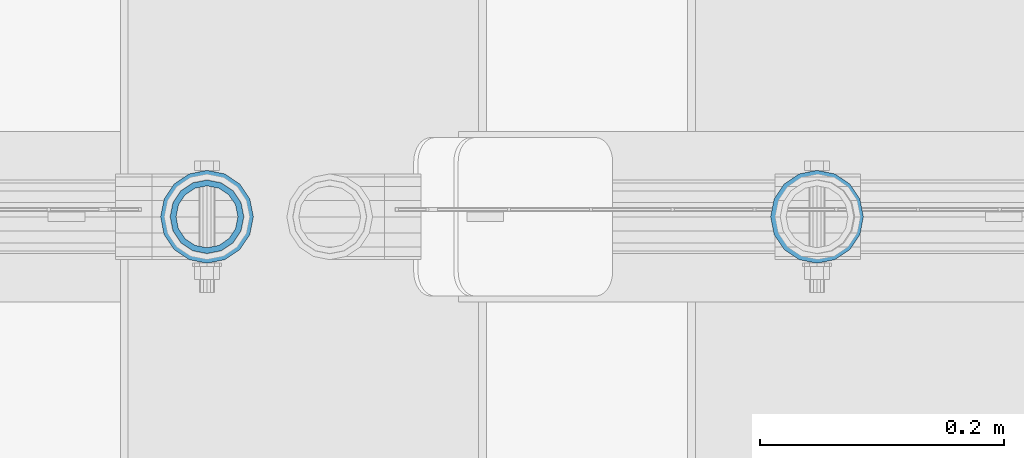
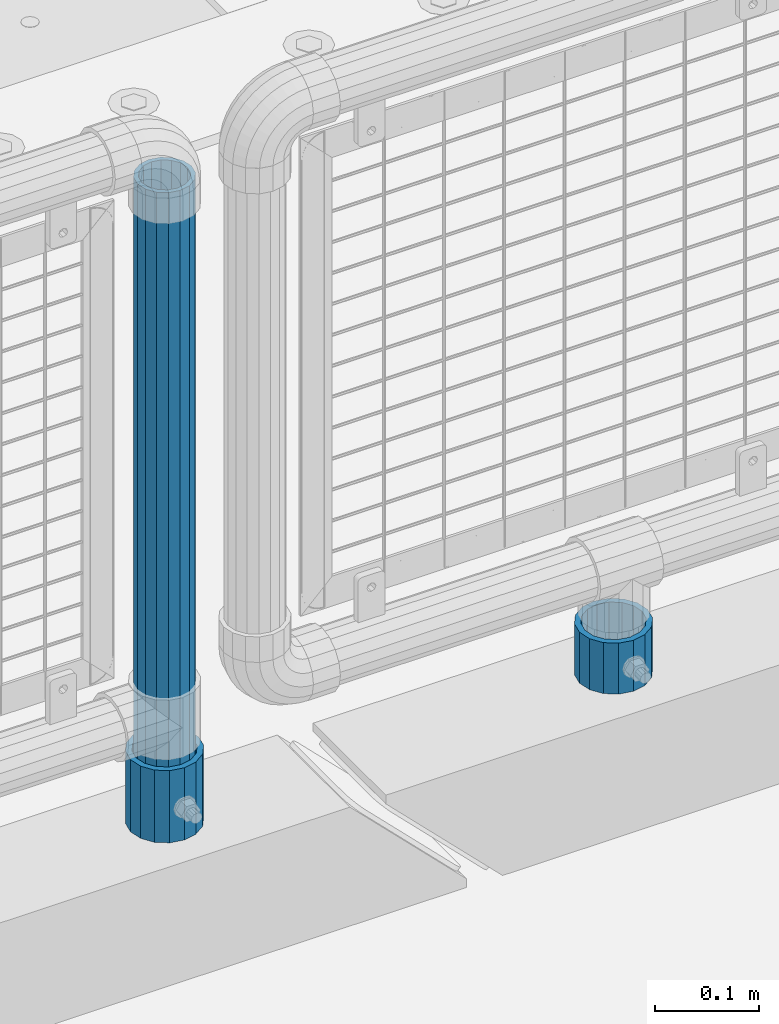
# One storey, part 102 of 247: 3 columns.
"""IFC2X3 building model written with IfcOpenShell, lengths in millimetres."""

from ifc_helpers import new_model, si_unit, frame, origin_with_axes, place, context, subcontext, project, spatial, faceted_brep, material, type_object, element, save


model = new_model("IFC2X3")

# Units and contexts
model_context = context("Model", 3, precision=1e-05, world=origin_with_axes())
body_context = subcontext(model_context, "Body", "Model", "MODEL_VIEW")
ifc_project = project(units=[si_unit("LENGTHUNIT", "METRE", prefix="MILLI"), si_unit("AREAUNIT", "SQUARE_METRE"), si_unit("VOLUMEUNIT", "CUBIC_METRE"), si_unit("MASSUNIT", "GRAM", prefix="KILO"), si_unit("TIMEUNIT", "SECOND"), si_unit("PLANEANGLEUNIT", "RADIAN"), si_unit("SOLIDANGLEUNIT", "STERADIAN"), si_unit("THERMODYNAMICTEMPERATUREUNIT", "DEGREE_CELSIUS"), si_unit("LUMINOUSINTENSITYUNIT", "LUMEN")], contexts=[model_context])

# Site, building, storey
site_placement = place(None, origin_with_axes())
site = spatial("IfcSite", under=ifc_project, at=site_placement, CompositionType="ELEMENT")
building_placement = place(site_placement, origin_with_axes())
building = spatial("IfcBuilding", under=site, at=building_placement, Name="Standard", CompositionType="ELEMENT")
storey_placement = place(building_placement, origin_with_axes())
storey = spatial("IfcBuildingStorey", under=building, at=storey_placement, Name="Undefined", CompositionType="ELEMENT", Elevation=0.0)

# Columns
ifc_material = material()
column_type_1 = type_object("IfcColumnType", PredefinedType="NOTDEFINED")
column_1_placement = place(storey_placement, frame((15020.9999998042, 7664.5, 168.019999999998), z_axis=(0.0, 1.0, 0.0), x_axis=(0.0, 0.0, 1.0)))
element("IfcColumn", 1, at=column_1_placement, inside=storey, type_object=column_type_1, material=ifc_material, context=body_context, shape_type="Brep", body=[
    faceted_brep([(0.0, -31.75, 0.0), (0.0, -29.3331751572332, 12.1501989775916), (85.0, -29.3331751572332, 12.1501989775916), (85.0, -31.75, 0.0), (0.0, -22.4506403026735, 22.4506403026726), (85.0, -22.4506403026735, 22.4506403026726), (0.0, -12.1501989775916, 29.3331751572332), (85.0, -12.1501989775916, 29.3331751572332), (0.0, 0.0, 31.75), (85.0, 0.0, 31.75), (0.0, 12.1501989775916, 29.3331751572332), (85.0, 12.1501989775916, 29.3331751572332), (0.0, 22.4506403026735, 22.4506403026726), (85.0, 22.4506403026735, 22.4506403026726), (0.0, 29.3331751572332, 12.1501989775916), (85.0, 29.3331751572332, 12.1501989775916), (0.0, 31.75, 0.0), (85.0, 31.75, 0.0), (0.0, 29.3331751572332, -12.1501989775916), (85.0, 29.3331751572332, -12.1501989775916), (0.0, 22.4506403026735, -22.4506403026726), (85.0, 22.4506403026735, -22.4506403026726), (0.0, 12.1501989775916, -29.3331751572332), (85.0, 12.1501989775916, -29.3331751572332), (0.0, 0.0, -31.75), (85.0, 0.0, -31.75), (0.0, -12.1501989775916, -29.3331751572332), (85.0, -12.1501989775916, -29.3331751572332), (0.0, -22.4506403026735, -22.4506403026726), (85.0, -22.4506403026735, -22.4506403026726), (0.0, -29.3331751572332, -12.1501989775916), (85.0, -29.3331751572332, -12.1501989775916), (0.0, -38.0499999999993, 0.0), (0.0, -35.1536162120537, -14.5611046014919), (85.0, -35.1536162120537, -14.5611046014919), (85.0, -38.0499999999993, 0.0), (0.0, -26.9054130241475, -26.9054130241484), (85.0, -26.9054130241475, -26.9054130241484), (0.0, -14.561104601491, -35.1536162120547), (85.0, -14.561104601491, -35.1536162120547), (0.0, 0.0, -38.0500000000002), (85.0, 0.0, -38.0500000000002), (0.0, 14.561104601491, -35.1536162120547), (85.0, 14.561104601491, -35.1536162120547), (0.0, 26.9054130241475, -26.9054130241484), (85.0, 26.9054130241475, -26.9054130241484), (0.0, 35.1536162120537, -14.5611046014919), (85.0, 35.1536162120537, -14.5611046014919), (0.0, 38.0499999999993, 0.0), (85.0, 38.0499999999993, 0.0), (0.0, 35.1536162120537, 14.5611046014919), (85.0, 35.1536162120537, 14.5611046014919), (0.0, 26.9054130241475, 26.9054130241484), (85.0, 26.9054130241475, 26.9054130241484), (0.0, 14.561104601491, 35.1536162120547), (85.0, 14.561104601491, 35.1536162120547), (0.0, 0.0, 38.0500000000002), (85.0, 0.0, 38.0500000000002), (0.0, -14.561104601491, 35.1536162120547), (85.0, -14.561104601491, 35.1536162120547), (0.0, -26.9054130241475, 26.9054130241484), (85.0, -26.9054130241475, 26.9054130241484), (0.0, -35.1536162120537, 14.5611046014919), (85.0, -35.1536162120537, 14.5611046014919)], [[[0, 1, 2, 3]], [[1, 4, 5, 2]], [[4, 6, 7, 5]], [[6, 8, 9, 7]], [[8, 10, 11, 9]], [[10, 12, 13, 11]], [[12, 14, 15, 13]], [[14, 16, 17, 15]], [[16, 18, 19, 17]], [[18, 20, 21, 19]], [[20, 22, 23, 21]], [[22, 24, 25, 23]], [[24, 26, 27, 25]], [[26, 28, 29, 27]], [[28, 30, 31, 29]], [[30, 0, 3, 31]], [[32, 33, 34, 35]], [[33, 36, 37, 34]], [[36, 38, 39, 37]], [[38, 40, 41, 39]], [[40, 42, 43, 41]], [[42, 44, 45, 43]], [[44, 46, 47, 45]], [[46, 48, 49, 47]], [[48, 50, 51, 49]], [[50, 52, 53, 51]], [[52, 54, 55, 53]], [[54, 56, 57, 55]], [[56, 58, 59, 57]], [[58, 60, 61, 59]], [[60, 62, 63, 61]], [[62, 32, 35, 63]], [[37, 39, 41, 43, 45, 47, 49, 51, 53, 55, 57, 59, 61, 63, 35, 34], [5, 7, 9, 11, 13, 15, 17, 19, 21, 23, 25, 27, 29, 31, 3, 2]], [[62, 60, 58, 56, 54, 52, 50, 48, 46, 44, 42, 40, 38, 36, 33, 32], [30, 28, 26, 24, 22, 20, 18, 16, 14, 12, 10, 8, 6, 4, 1, 0]]]),
])
column_2_placement = place(storey_placement, frame((15521.0, 7664.5, 168.019999999998), z_axis=(0.0, 1.0, 0.0), x_axis=(0.0, 0.0, 1.0)))
element("IfcColumn", 2, at=column_2_placement, inside=storey, type_object=column_type_1, material=ifc_material, context=body_context, shape_type="Brep", body=[
    faceted_brep([(0.0, -31.75, 0.0), (0.0, -29.3331751572332, 12.1501989775916), (60.0, -29.3331751572332, 12.1501989775916), (60.0, -31.75, 0.0), (0.0, -22.4506403026735, 22.4506403026726), (60.0, -22.4506403026735, 22.4506403026726), (0.0, -12.1501989775916, 29.3331751572332), (60.0, -12.1501989775916, 29.3331751572332), (0.0, 0.0, 31.75), (60.0, 0.0, 31.75), (0.0, 12.1501989775916, 29.3331751572332), (60.0, 12.1501989775916, 29.3331751572332), (0.0, 22.4506403026735, 22.4506403026726), (60.0, 22.4506403026735, 22.4506403026726), (0.0, 29.3331751572332, 12.1501989775916), (60.0, 29.3331751572332, 12.1501989775916), (0.0, 31.75, 0.0), (60.0, 31.75, 0.0), (0.0, 29.3331751572332, -12.1501989775916), (60.0, 29.3331751572332, -12.1501989775916), (0.0, 22.4506403026735, -22.4506403026726), (60.0, 22.4506403026735, -22.4506403026726), (0.0, 12.1501989775916, -29.3331751572332), (60.0, 12.1501989775916, -29.3331751572332), (0.0, 0.0, -31.75), (60.0, 0.0, -31.75), (0.0, -12.1501989775916, -29.3331751572332), (60.0, -12.1501989775916, -29.3331751572332), (0.0, -22.4506403026735, -22.4506403026726), (60.0, -22.4506403026735, -22.4506403026726), (0.0, -29.3331751572332, -12.1501989775916), (60.0, -29.3331751572332, -12.1501989775916), (0.0, -38.0499999999993, 0.0), (0.0, -35.1536162120537, -14.5611046014919), (60.0, -35.1536162120537, -14.5611046014919), (60.0, -38.0499999999993, 0.0), (0.0, -26.9054130241475, -26.9054130241484), (60.0, -26.9054130241475, -26.9054130241484), (0.0, -14.561104601491, -35.1536162120547), (60.0, -14.561104601491, -35.1536162120547), (0.0, 0.0, -38.0500000000002), (60.0, 0.0, -38.0500000000002), (0.0, 14.561104601491, -35.1536162120547), (60.0, 14.561104601491, -35.1536162120547), (0.0, 26.9054130241475, -26.9054130241484), (60.0, 26.9054130241475, -26.9054130241484), (0.0, 35.1536162120537, -14.5611046014919), (60.0, 35.1536162120537, -14.5611046014919), (0.0, 38.0499999999993, 0.0), (60.0, 38.0499999999993, 0.0), (0.0, 35.1536162120537, 14.5611046014919), (60.0, 35.1536162120537, 14.5611046014919), (0.0, 26.9054130241475, 26.9054130241484), (60.0, 26.9054130241475, 26.9054130241484), (0.0, 14.561104601491, 35.1536162120547), (60.0, 14.561104601491, 35.1536162120547), (0.0, 0.0, 38.0500000000002), (60.0, 0.0, 38.0500000000002), (0.0, -14.561104601491, 35.1536162120547), (60.0, -14.561104601491, 35.1536162120547), (0.0, -26.9054130241475, 26.9054130241484), (60.0, -26.9054130241475, 26.9054130241484), (0.0, -35.1536162120537, 14.5611046014919), (60.0, -35.1536162120537, 14.5611046014919)], [[[0, 1, 2, 3]], [[1, 4, 5, 2]], [[4, 6, 7, 5]], [[6, 8, 9, 7]], [[8, 10, 11, 9]], [[10, 12, 13, 11]], [[12, 14, 15, 13]], [[14, 16, 17, 15]], [[16, 18, 19, 17]], [[18, 20, 21, 19]], [[20, 22, 23, 21]], [[22, 24, 25, 23]], [[24, 26, 27, 25]], [[26, 28, 29, 27]], [[28, 30, 31, 29]], [[30, 0, 3, 31]], [[32, 33, 34, 35]], [[33, 36, 37, 34]], [[36, 38, 39, 37]], [[38, 40, 41, 39]], [[40, 42, 43, 41]], [[42, 44, 45, 43]], [[44, 46, 47, 45]], [[46, 48, 49, 47]], [[48, 50, 51, 49]], [[50, 52, 53, 51]], [[52, 54, 55, 53]], [[54, 56, 57, 55]], [[56, 58, 59, 57]], [[58, 60, 61, 59]], [[60, 62, 63, 61]], [[62, 32, 35, 63]], [[37, 39, 41, 43, 45, 47, 49, 51, 53, 55, 57, 59, 61, 63, 35, 34], [5, 7, 9, 11, 13, 15, 17, 19, 21, 23, 25, 27, 29, 31, 3, 2]], [[62, 60, 58, 56, 54, 52, 50, 48, 46, 44, 42, 40, 38, 36, 33, 32], [30, 28, 26, 24, 22, 20, 18, 16, 14, 12, 10, 8, 6, 4, 1, 0]]]),
])
column_type_2 = type_object("IfcColumnType", PredefinedType="NOTDEFINED")
column_3_placement = place(storey_placement, frame((15020.9999998042, 7664.5, 168.019999999998), z_axis=(-1.0, 0.0, 0.0), x_axis=(0.0, 0.0, 1.0)))
element("IfcColumn", 3, at=column_3_placement, inside=storey, type_object=column_type_2, material=ifc_material, context=body_context, shape_type="Brep", body=[
    faceted_brep([(0.0, -25.3500000000004, 0.0), (0.0, -23.4203461491616, 9.70102501045585), (760.0, -23.4203461491616, 9.70102501045585), (760.0, -25.3500000000004, 0.0), (0.0, -17.9251569030794, 17.9251569030785), (760.0, -17.9251569030794, 17.9251569030785), (0.0, -9.70102501045494, 23.4203461491616), (760.0, -9.70102501045494, 23.4203461491616), (0.0, 0.0, 25.3500000000004), (760.0, 0.0, 25.3500000000004), (0.0, 9.70102501045494, 23.4203461491616), (760.0, 9.70102501045494, 23.4203461491616), (0.0, 17.9251569030794, 17.9251569030785), (760.0, 17.9251569030794, 17.9251569030785), (0.0, 23.4203461491616, 9.70102501045585), (760.0, 23.4203461491616, 9.70102501045585), (0.0, 25.3500000000004, 0.0), (760.0, 25.3500000000004, 0.0), (0.0, 23.4203461491616, -9.70102501045585), (760.0, 23.4203461491616, -9.70102501045585), (0.0, 17.9251569030794, -17.9251569030785), (760.0, 17.9251569030794, -17.9251569030785), (0.0, 9.70102501045494, -23.4203461491616), (760.0, 9.70102501045494, -23.4203461491616), (0.0, 0.0, -25.3500000000004), (760.0, 0.0, -25.3500000000004), (0.0, -9.70102501045494, -23.4203461491616), (760.0, -9.70102501045494, -23.4203461491616), (0.0, -17.9251569030794, -17.9251569030785), (760.0, -17.9251569030794, -17.9251569030785), (0.0, -23.4203461491616, -9.70102501045585), (760.0, -23.4203461491616, -9.70102501045585), (0.0, -30.1499999999996, 0.0), (0.0, -27.8549679052148, -11.5379054858076), (760.0, -27.8549679052148, -11.5379054858076), (760.0, -30.1499999999996, 0.0), (0.0, -21.3192694527743, -21.3192694527752), (760.0, -21.3192694527743, -21.3192694527752), (0.0, -11.5379054858076, -27.8549679052157), (760.0, -11.5379054858076, -27.8549679052157), (0.0, 0.0, -30.1499999999996), (760.0, 0.0, -30.1499999999996), (0.0, 11.5379054858076, -27.8549679052157), (760.0, 11.5379054858076, -27.8549679052157), (0.0, 21.3192694527743, -21.3192694527752), (760.0, 21.3192694527743, -21.3192694527752), (0.0, 27.8549679052157, -11.5379054858076), (760.0, 27.8549679052157, -11.5379054858076), (0.0, 30.1499999999996, 0.0), (760.0, 30.1499999999996, 0.0), (0.0, 27.8549679052157, 11.5379054858076), (760.0, 27.8549679052157, 11.5379054858076), (0.0, 21.3192694527743, 21.3192694527752), (760.0, 21.3192694527743, 21.3192694527752), (0.0, 11.5379054858076, 27.8549679052157), (760.0, 11.5379054858076, 27.8549679052157), (0.0, 0.0, 30.1499999999996), (760.0, 0.0, 30.1499999999996), (0.0, -11.5379054858076, 27.8549679052157), (760.0, -11.5379054858076, 27.8549679052157), (0.0, -21.3192694527743, 21.3192694527752), (760.0, -21.3192694527743, 21.3192694527752), (0.0, -27.8549679052157, 11.5379054858076), (760.0, -27.8549679052157, 11.5379054858076)], [[[0, 1, 2, 3]], [[1, 4, 5, 2]], [[4, 6, 7, 5]], [[6, 8, 9, 7]], [[8, 10, 11, 9]], [[10, 12, 13, 11]], [[12, 14, 15, 13]], [[14, 16, 17, 15]], [[16, 18, 19, 17]], [[18, 20, 21, 19]], [[20, 22, 23, 21]], [[22, 24, 25, 23]], [[24, 26, 27, 25]], [[26, 28, 29, 27]], [[28, 30, 31, 29]], [[30, 0, 3, 31]], [[32, 33, 34, 35]], [[33, 36, 37, 34]], [[36, 38, 39, 37]], [[38, 40, 41, 39]], [[40, 42, 43, 41]], [[42, 44, 45, 43]], [[44, 46, 47, 45]], [[46, 48, 49, 47]], [[48, 50, 51, 49]], [[50, 52, 53, 51]], [[52, 54, 55, 53]], [[54, 56, 57, 55]], [[56, 58, 59, 57]], [[58, 60, 61, 59]], [[60, 62, 63, 61]], [[62, 32, 35, 63]], [[37, 39, 41, 43, 45, 47, 49, 51, 53, 55, 57, 59, 61, 63, 35, 34], [5, 7, 9, 11, 13, 15, 17, 19, 21, 23, 25, 27, 29, 31, 3, 2]], [[62, 60, 58, 56, 54, 52, 50, 48, 46, 44, 42, 40, 38, 36, 33, 32], [30, 28, 26, 24, 22, 20, 18, 16, 14, 12, 10, 8, 6, 4, 1, 0]]]),
])

save(model, "model.ifc")
